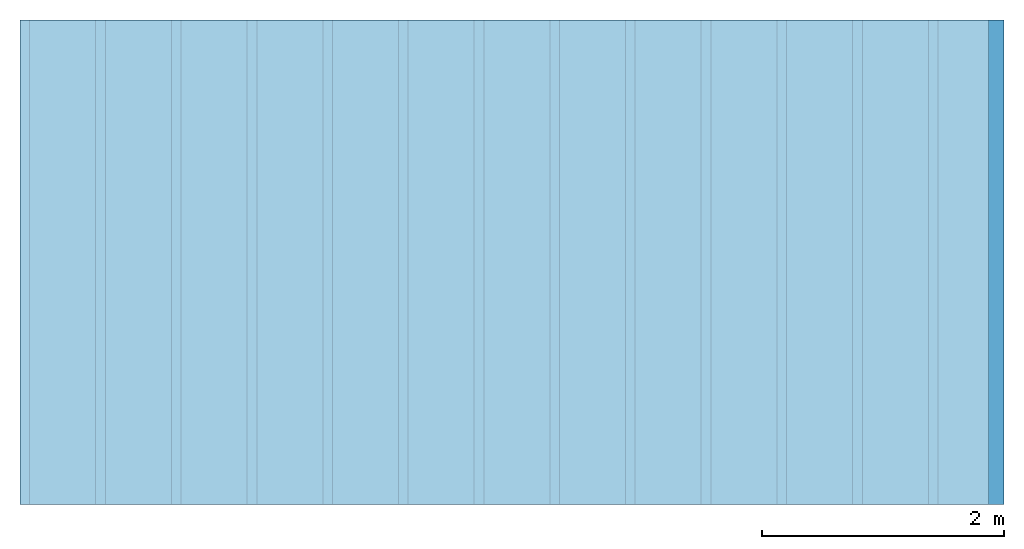
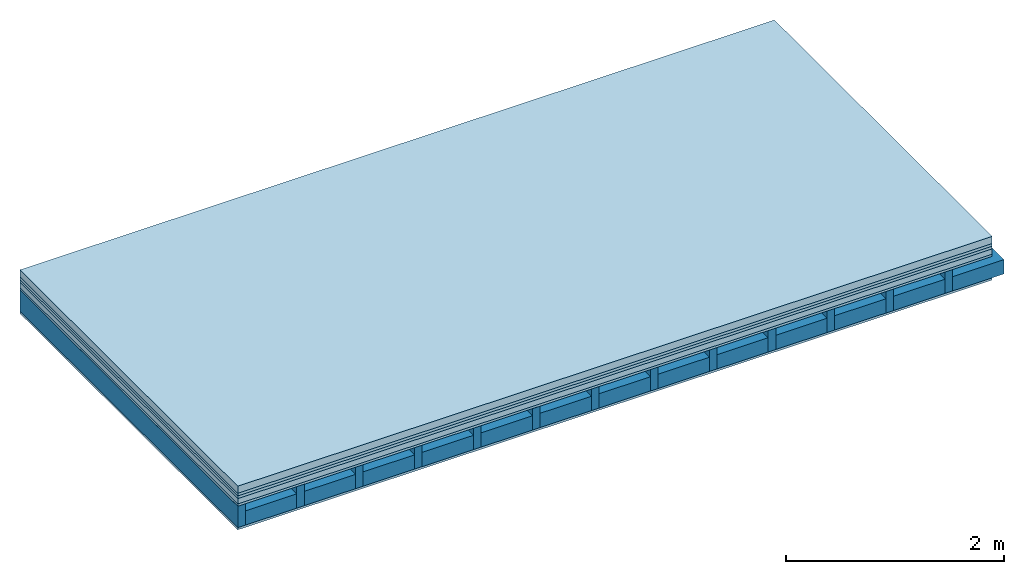
# One storey: 6 plates, 2 members, 1 element without a shape of its own.
"""IFC4 building model written with IfcOpenShell, lengths in metres."""

from ifc_helpers import new_model, si_unit, derived_unit, direction, frame, frame_2d, origin, origin_with_axes, place, context, project, spatial, rectangle, extrude, material, layer, layer_set, type_object, element, aggregate, save


model = new_model("IFC4")

# Units and contexts
plan_context = context("Plan", 3, precision=1e-05, world=origin(), true_north=direction((0.0, 1.0)))
model_context = context("Model", 3, precision=1e-05, world=origin(), true_north=direction((0.0, 1.0)))
ifc_project = project(units=[si_unit("LENGTHUNIT", "METRE"), derived_unit("SOUNDPRESSUREUNIT", [(si_unit("PRESSUREUNIT", "PASCAL", prefix="MICRO"), 0)]), si_unit("ENERGYUNIT", "JOULE", prefix="MEGA"), si_unit("MASSUNIT", "GRAM", prefix="KILO"), derived_unit("THERMALTRANSMITTANCEUNIT", [(si_unit("POWERUNIT", "WATT"), 1), (si_unit("AREAUNIT", "SQUARE_METRE"), -1), (si_unit("THERMODYNAMICTEMPERATUREUNIT", "KELVIN"), -1)]), derived_unit("AREADENSITYUNIT", [(si_unit("MASSUNIT", "GRAM", prefix="KILO"), 1), (si_unit("AREAUNIT", "SQUARE_METRE"), -1)]), derived_unit("USERDEFINED", [(si_unit("ENERGYUNIT", "JOULE", prefix="MEGA"), 1), (si_unit("AREAUNIT", "SQUARE_METRE"), -1)])], contexts=[plan_context, model_context])

# Site, building, storey
site = spatial("IfcSite", under=ifc_project)
building_placement = place(None, origin())
building = spatial("IfcBuilding", under=site, at=building_placement)
storey_placement = place(building_placement, origin())
storey = spatial("IfcBuildingStorey", under=building, at=storey_placement)

# Slab, members, plates
ifc_material_1 = material(Name="Cement screed", Category="04.006")
ifc_layer_1 = layer(ifc_material_1, 0.08, Name="On-material")
ifc_material_2 = material()
ifc_layer_2 = layer(ifc_material_2, 0.03, Name="Impact sound insulation")
ifc_material_3 = material()
ifc_layer_3 = layer(ifc_material_3, 0.03, Name="Additional insulation")
ifc_material_4 = material(Category="03.011")
ifc_layer_4 = layer(ifc_material_4, 0.06, Name="on Supporting structure")
ifc_material_5 = material(Category="07.001")
ifc_layer_5 = layer(ifc_material_5, 0.025, Name="Sub-floor")
ifc_material_6 = material(Name="Rigid, of the art")
ifc_layer_6 = layer(ifc_material_6, 0.0, Name="Bond")
ifc_layer_7 = layer(None, 0.24, Name="Supporting structure")
ifc_layer_8 = layer(ifc_material_6, 0.0, Name="Bond")
ifc_layer_9 = layer(ifc_material_5, 0.025, Name="Lower layer 1")
ifc_layer_set = layer_set([ifc_layer_1, ifc_layer_2, ifc_layer_3, ifc_layer_4, ifc_layer_5, ifc_layer_6, ifc_layer_7, ifc_layer_8, ifc_layer_9])
slab_type = type_object("IfcSlabType", Name="A0437", PredefinedType="NOTDEFINED", material=ifc_layer_set)
slab_placement = place(None, frame((0.0, 0.0, 0.0), z_axis=(0.0, 0.0, -1.0), x_axis=(1.0, 0.0, 0.0)))
slab = element("IfcSlab", 1, at=slab_placement, inside=storey, type_object=slab_type, material=ifc_layer_set, Name="Slab #1")
ifc_material_7 = material()
member_1_placement = place(slab_placement, origin())
member_1 = element("IfcMember", 2, at=member_1_placement, material=ifc_material_7, Name="Supporting structure", context=plan_context, shape_type="SweptSolid", body=[
    extrude(rectangle(XDim=0.08, YDim=0.24, at=frame_2d((0.04, 0.12), x_axis=(1.0, 0.0))), frame((0.0, 4.0, 0.225), z_axis=(0.0, -1.0, 0.0), x_axis=(1.0, 0.0, 0.0)), (0.0, 0.0, 1.0), 4.0),
    extrude(rectangle(XDim=0.08, YDim=0.24, at=frame_2d((0.04, 0.12), x_axis=(1.0, 0.0))), frame((0.625, 4.0, 0.225), z_axis=(0.0, -1.0, 0.0), x_axis=(1.0, 0.0, 0.0)), (0.0, 0.0, 1.0), 4.0),
    extrude(rectangle(XDim=0.08, YDim=0.24, at=frame_2d((0.04, 0.12), x_axis=(1.0, 0.0))), frame((1.25, 4.0, 0.225), z_axis=(0.0, -1.0, 0.0), x_axis=(1.0, 0.0, 0.0)), (0.0, 0.0, 1.0), 4.0),
    extrude(rectangle(XDim=0.08, YDim=0.24, at=frame_2d((0.04, 0.12), x_axis=(1.0, 0.0))), frame((1.875, 4.0, 0.225), z_axis=(0.0, -1.0, 0.0), x_axis=(1.0, 0.0, 0.0)), (0.0, 0.0, 1.0), 4.0),
    extrude(rectangle(XDim=0.08, YDim=0.24, at=frame_2d((0.04, 0.12), x_axis=(1.0, 0.0))), frame((2.5, 4.0, 0.225), z_axis=(0.0, -1.0, 0.0), x_axis=(1.0, 0.0, 0.0)), (0.0, 0.0, 1.0), 4.0),
    extrude(rectangle(XDim=0.08, YDim=0.24, at=frame_2d((0.04, 0.12), x_axis=(1.0, 0.0))), frame((3.125, 4.0, 0.225), z_axis=(0.0, -1.0, 0.0), x_axis=(1.0, 0.0, 0.0)), (0.0, 0.0, 1.0), 4.0),
    extrude(rectangle(XDim=0.08, YDim=0.24, at=frame_2d((0.04, 0.12), x_axis=(1.0, 0.0))), frame((3.75, 4.0, 0.225), z_axis=(0.0, -1.0, 0.0), x_axis=(1.0, 0.0, 0.0)), (0.0, 0.0, 1.0), 4.0),
    extrude(rectangle(XDim=0.08, YDim=0.24, at=frame_2d((0.04, 0.12), x_axis=(1.0, 0.0))), frame((4.375, 4.0, 0.225), z_axis=(0.0, -1.0, 0.0), x_axis=(1.0, 0.0, 0.0)), (0.0, 0.0, 1.0), 4.0),
    extrude(rectangle(XDim=0.08, YDim=0.24, at=frame_2d((0.04, 0.12), x_axis=(1.0, 0.0))), frame((5.0, 4.0, 0.225), z_axis=(0.0, -1.0, 0.0), x_axis=(1.0, 0.0, 0.0)), (0.0, 0.0, 1.0), 4.0),
    extrude(rectangle(XDim=0.08, YDim=0.24, at=frame_2d((0.04, 0.12), x_axis=(1.0, 0.0))), frame((5.625, 4.0, 0.225), z_axis=(0.0, -1.0, 0.0), x_axis=(1.0, 0.0, 0.0)), (0.0, 0.0, 1.0), 4.0),
    extrude(rectangle(XDim=0.08, YDim=0.24, at=frame_2d((0.04, 0.12), x_axis=(1.0, 0.0))), frame((6.25, 4.0, 0.225), z_axis=(0.0, -1.0, 0.0), x_axis=(1.0, 0.0, 0.0)), (0.0, 0.0, 1.0), 4.0),
    extrude(rectangle(XDim=0.08, YDim=0.24, at=frame_2d((0.04, 0.12), x_axis=(1.0, 0.0))), frame((6.875, 4.0, 0.225), z_axis=(0.0, -1.0, 0.0), x_axis=(1.0, 0.0, 0.0)), (0.0, 0.0, 1.0), 4.0),
    extrude(rectangle(XDim=0.08, YDim=0.24, at=frame_2d((0.04, 0.12), x_axis=(1.0, 0.0))), frame((7.5, 4.0, 0.225), z_axis=(0.0, -1.0, 0.0), x_axis=(1.0, 0.0, 0.0)), (0.0, 0.0, 1.0), 4.0),
])
ifc_material_8 = material()
member_2_placement = place(slab_placement, origin())
member_2 = element("IfcMember", 3, at=member_2_placement, material=ifc_material_8, Name="Cavity", context=plan_context, shape_type="SweptSolid", body=[
    extrude(rectangle(XDim=0.545, YDim=0.16, at=frame_2d((0.2725, 0.08), x_axis=(1.0, 0.0))), frame((0.08, 4.0, 0.305), z_axis=(0.0, -1.0, 0.0), x_axis=(1.0, 0.0, 0.0)), (0.0, 0.0, 1.0), 4.0),
    extrude(rectangle(XDim=0.545, YDim=0.16, at=frame_2d((0.2725, 0.08), x_axis=(1.0, 0.0))), frame((0.705, 4.0, 0.305), z_axis=(0.0, -1.0, 0.0), x_axis=(1.0, 0.0, 0.0)), (0.0, 0.0, 1.0), 4.0),
    extrude(rectangle(XDim=0.545, YDim=0.16, at=frame_2d((0.2725, 0.08), x_axis=(1.0, 0.0))), frame((1.33, 4.0, 0.305), z_axis=(0.0, -1.0, 0.0), x_axis=(1.0, 0.0, 0.0)), (0.0, 0.0, 1.0), 4.0),
    extrude(rectangle(XDim=0.545, YDim=0.16, at=frame_2d((0.2725, 0.08), x_axis=(1.0, 0.0))), frame((1.955, 4.0, 0.305), z_axis=(0.0, -1.0, 0.0), x_axis=(1.0, 0.0, 0.0)), (0.0, 0.0, 1.0), 4.0),
    extrude(rectangle(XDim=0.545, YDim=0.16, at=frame_2d((0.2725, 0.08), x_axis=(1.0, 0.0))), frame((2.58, 4.0, 0.305), z_axis=(0.0, -1.0, 0.0), x_axis=(1.0, 0.0, 0.0)), (0.0, 0.0, 1.0), 4.0),
    extrude(rectangle(XDim=0.545, YDim=0.16, at=frame_2d((0.2725, 0.08), x_axis=(1.0, 0.0))), frame((3.205, 4.0, 0.305), z_axis=(0.0, -1.0, 0.0), x_axis=(1.0, 0.0, 0.0)), (0.0, 0.0, 1.0), 4.0),
    extrude(rectangle(XDim=0.545, YDim=0.16, at=frame_2d((0.2725, 0.08), x_axis=(1.0, 0.0))), frame((3.83, 4.0, 0.305), z_axis=(0.0, -1.0, 0.0), x_axis=(1.0, 0.0, 0.0)), (0.0, 0.0, 1.0), 4.0),
    extrude(rectangle(XDim=0.545, YDim=0.16, at=frame_2d((0.2725, 0.08), x_axis=(1.0, 0.0))), frame((4.455, 4.0, 0.305), z_axis=(0.0, -1.0, 0.0), x_axis=(1.0, 0.0, 0.0)), (0.0, 0.0, 1.0), 4.0),
    extrude(rectangle(XDim=0.545, YDim=0.16, at=frame_2d((0.2725, 0.08), x_axis=(1.0, 0.0))), frame((5.08, 4.0, 0.305), z_axis=(0.0, -1.0, 0.0), x_axis=(1.0, 0.0, 0.0)), (0.0, 0.0, 1.0), 4.0),
    extrude(rectangle(XDim=0.545, YDim=0.16, at=frame_2d((0.2725, 0.08), x_axis=(1.0, 0.0))), frame((5.705, 4.0, 0.305), z_axis=(0.0, -1.0, 0.0), x_axis=(1.0, 0.0, 0.0)), (0.0, 0.0, 1.0), 4.0),
    extrude(rectangle(XDim=0.545, YDim=0.16, at=frame_2d((0.2725, 0.08), x_axis=(1.0, 0.0))), frame((6.33, 4.0, 0.305), z_axis=(0.0, -1.0, 0.0), x_axis=(1.0, 0.0, 0.0)), (0.0, 0.0, 1.0), 4.0),
    extrude(rectangle(XDim=0.545, YDim=0.16, at=frame_2d((0.2725, 0.08), x_axis=(1.0, 0.0))), frame((6.955, 4.0, 0.305), z_axis=(0.0, -1.0, 0.0), x_axis=(1.0, 0.0, 0.0)), (0.0, 0.0, 1.0), 4.0),
    extrude(rectangle(XDim=0.545, YDim=0.16, at=frame_2d((0.2725, 0.08), x_axis=(1.0, 0.0))), frame((7.58, 4.0, 0.305), z_axis=(0.0, -1.0, 0.0), x_axis=(1.0, 0.0, 0.0)), (0.0, 0.0, 1.0), 4.0),
])
plate_1_placement = place(slab_placement, origin())
plate_1 = element("IfcPlate", 4, at=plate_1_placement, material=ifc_material_1, Name="On-material", context=plan_context, shape_type="SweptSolid", body=[
    extrude(rectangle(XDim=8.0, YDim=4.0, at=frame_2d((4.0, 2.0), x_axis=(1.0, 0.0))), origin_with_axes(), (0.0, 0.0, 1.0), 0.08),
])
plate_2_placement = place(slab_placement, origin())
plate_2 = element("IfcPlate", 5, at=plate_2_placement, material=ifc_material_2, Name="Impact sound insulation", context=plan_context, shape_type="SweptSolid", body=[
    extrude(rectangle(XDim=8.0, YDim=4.0, at=frame_2d((4.0, 2.0), x_axis=(1.0, 0.0))), frame((0.0, 0.0, 0.08), z_axis=(0.0, 0.0, 1.0), x_axis=(1.0, 0.0, 0.0)), (0.0, 0.0, 1.0), 0.03),
])
plate_3_placement = place(slab_placement, origin())
plate_3 = element("IfcPlate", 6, at=plate_3_placement, material=ifc_material_3, Name="Additional insulation", context=plan_context, shape_type="SweptSolid", body=[
    extrude(rectangle(XDim=8.0, YDim=4.0, at=frame_2d((4.0, 2.0), x_axis=(1.0, 0.0))), frame((0.0, 0.0, 0.11), z_axis=(0.0, 0.0, 1.0), x_axis=(1.0, 0.0, 0.0)), (0.0, 0.0, 1.0), 0.03),
])
plate_4_placement = place(slab_placement, origin())
plate_4 = element("IfcPlate", 7, at=plate_4_placement, material=ifc_material_4, Name="on Supporting structure", context=plan_context, shape_type="SweptSolid", body=[
    extrude(rectangle(XDim=8.0, YDim=4.0, at=frame_2d((4.0, 2.0), x_axis=(1.0, 0.0))), frame((0.0, 0.0, 0.14), z_axis=(0.0, 0.0, 1.0), x_axis=(1.0, 0.0, 0.0)), (0.0, 0.0, 1.0), 0.06),
])
plate_5_placement = place(slab_placement, origin())
plate_5 = element("IfcPlate", 8, at=plate_5_placement, material=ifc_material_5, Name="Sub-floor", context=plan_context, shape_type="SweptSolid", body=[
    extrude(rectangle(XDim=8.0, YDim=4.0, at=frame_2d((4.0, 2.0), x_axis=(1.0, 0.0))), frame((0.0, 0.0, 0.2), z_axis=(0.0, 0.0, 1.0), x_axis=(1.0, 0.0, 0.0)), (0.0, 0.0, 1.0), 0.025),
])
plate_6_placement = place(slab_placement, origin())
plate_6 = element("IfcPlate", 9, at=plate_6_placement, material=ifc_material_5, Name="Lower layer 1", context=plan_context, shape_type="SweptSolid", body=[
    extrude(rectangle(XDim=8.0, YDim=4.0, at=frame_2d((4.0, 2.0), x_axis=(1.0, 0.0))), frame((0.0, 0.0, 0.465), z_axis=(0.0, 0.0, 1.0), x_axis=(1.0, 0.0, 0.0)), (0.0, 0.0, 1.0), 0.025),
])
aggregate(slab, [plate_1, plate_2, plate_3, plate_4, plate_5, member_1, member_2, plate_6])

save(model, "model.ifc")
